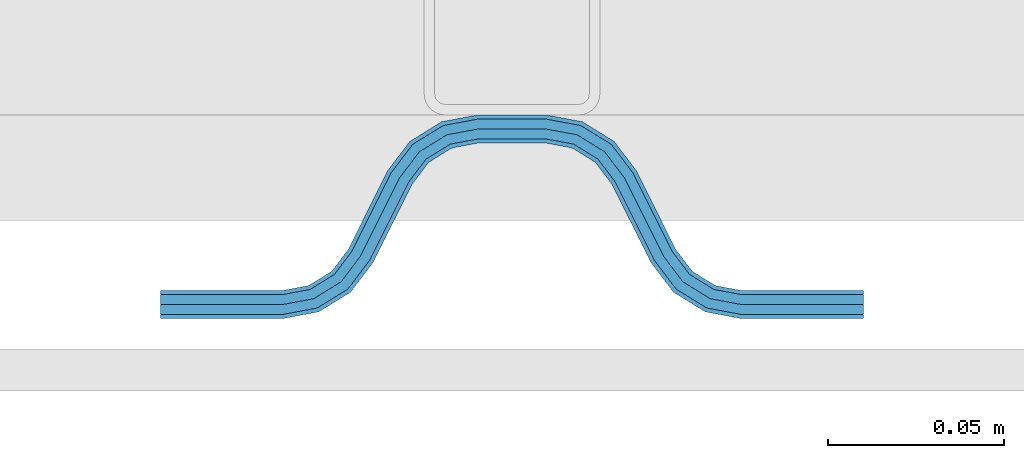
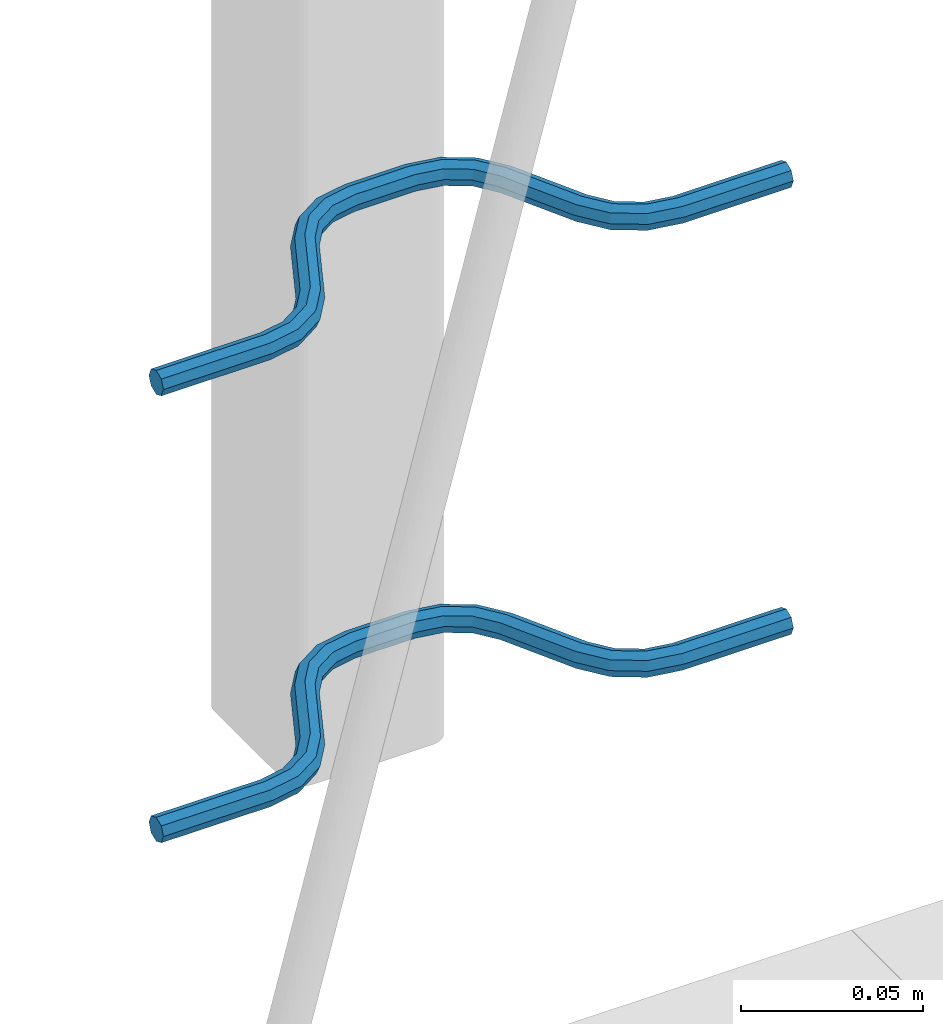
# One storey, part 5 of 5: 2 beams, 2 elements without a shape of their own.
"""IFC2X3 building model written with IfcOpenShell, lengths in millimetres."""

import ifcopenshell
import ifcopenshell.guid

model = None  # the IFC model being written
_history = None  # IfcOwnerHistory: only IFC2X3 demands one
_inside = {}  # id of a spatial element -> (the spatial element, [elements in it])
_under = {}  # id of a project, library or spatial element -> (it, [spatial elements below it])
_declared = {}  # id of a project -> (the project, [libraries it declares])
_typed = {}  # id of a type object -> (the type object, [elements of that type])
_made_of = {}  # id of a material, layer set ... -> (it, [elements and type objects made of it])


def new_model(schema):
    """Start an empty IFC model of exactly this schema.

    Asked for "IFC4X3", IfcOpenShell would pick the latest addendum, in which some entities
    have other attributes; the version numbers below select the first issue.
    IFC2X3 requires an IfcOwnerHistory on every rooted entity: one is made here for all.
    """
    global model, _history
    if schema == "IFC4X3":
        model = ifcopenshell.file(schema_version=(4, 3, 0, 0))
    else:
        model = ifcopenshell.file(schema=schema)
    _inside.clear()
    _under.clear()
    _declared.clear()
    _typed.clear()
    _made_of.clear()
    _history = None
    if model.schema == "IFC2X3":
        org = make("IfcOrganization", Name="unknown")
        user = make(
            "IfcPersonAndOrganization",
            ThePerson=make("IfcPerson", FamilyName="unknown"),
            TheOrganization=org,
        )
        app = make(
            "IfcApplication",
            ApplicationDeveloper=org,
            Version="unknown",
            ApplicationFullName="unknown",
            ApplicationIdentifier="unknown",
        )
        _history = make(
            "IfcOwnerHistory",
            OwningUser=user,
            OwningApplication=app,
            ChangeAction="ADDED",
            CreationDate=0,
        )
    return model


def make(cls, **values):
    """One entity of the class cls with the attributes given. An attribute that is None is left unset."""
    return model.create_entity(
        cls, **{name: value for name, value in values.items() if value is not None}
    )


def rooted(cls, **values):
    """An entity with a GlobalId (a new one), such as an element, a storey or a relation."""
    return make(cls, GlobalId=ifcopenshell.guid.new(), OwnerHistory=_history, **values)


def si_unit(unit_type, name, prefix=None):
    """IfcSIUnit, for example si_unit("LENGTHUNIT", "METRE", prefix="MILLI")."""
    return make("IfcSIUnit", UnitType=unit_type, Prefix=prefix, Name=name)


def assignment(units):
    """IfcUnitAssignment: the units of a project."""
    return None if units is None else make("IfcUnitAssignment", Units=units)


def point(xyz):
    """IfcCartesianPoint."""
    return None if xyz is None else make("IfcCartesianPoint", Coordinates=xyz)


def direction(xyz):
    """IfcDirection."""
    return None if xyz is None else make("IfcDirection", DirectionRatios=xyz)


def frame(location, z_axis=None, x_axis=None):
    """IfcAxis2Placement3D, a coordinate frame: its origin and axes. An axis left out is left unset."""
    return make(
        "IfcAxis2Placement3D",
        Location=point(location),
        Axis=direction(z_axis),
        RefDirection=direction(x_axis),
    )


def origin_with_axes():
    """The frame at (0, 0, 0) with the z axis (0, 0, 1) and the x axis (1, 0, 0) written out."""
    return frame((0.0, 0.0, 0.0), z_axis=(0.0, 0.0, 1.0), x_axis=(1.0, 0.0, 0.0))


def place(relative_to, where):
    """IfcLocalPlacement: puts the frame where relative to a parent placement (None: the world)."""
    return make(
        "IfcLocalPlacement", PlacementRelTo=relative_to, RelativePlacement=where
    )


def context(
    kind, dimensions, precision=None, world=None, true_north=None, identifier=None
):
    """IfcGeometricRepresentationContext, for example the 3D "Model" context."""
    return make(
        "IfcGeometricRepresentationContext",
        ContextIdentifier=identifier,
        ContextType=kind,
        CoordinateSpaceDimension=dimensions,
        Precision=precision,
        WorldCoordinateSystem=world,
        TrueNorth=true_north,
    )


def subcontext(parent, identifier, kind, view, scale=None):
    """IfcGeometricRepresentationSubContext, for example "Body" below "Model"."""
    return make(
        "IfcGeometricRepresentationSubContext",
        ContextIdentifier=identifier,
        ContextType=kind,
        ParentContext=parent,
        TargetScale=scale,
        TargetView=view,
    )


def project(units=None, contexts=None):
    """IfcProject with its units and contexts."""
    return rooted(
        "IfcProject",
        Name="project",
        RepresentationContexts=contexts,
        UnitsInContext=assignment(units),
    )


def spatial(cls, under=None, at=None, **own):
    """A site, building, storey or space (cls), placed at a placement, below another one or the project."""
    s = rooted(cls, ObjectPlacement=at, **own)
    if under is not None:
        _under.setdefault(under.id(), (under, []))[1].append(s)
    return s


def faces_of(points, faces, orient=None, outer=None):
    """IfcFace entities. A face is a list of loops; a loop is a list of indices into points, from 0.

    orient and outer hold one flag for each loop. By default every Orientation is true, the
    first loop of a face is its IfcFaceOuterBound and the others are IfcFaceBound.
    """
    made = []
    for i, loops in enumerate(faces):
        bounds = []
        for j, loop in enumerate(loops):
            is_outer = j == 0 if outer is None else outer[i][j]
            bounds.append(
                make(
                    "IfcFaceOuterBound" if is_outer else "IfcFaceBound",
                    Bound=make("IfcPolyLoop", Polygon=[points[k] for k in loop]),
                    Orientation=True if orient is None else orient[i][j],
                )
            )
        made.append(make("IfcFace", Bounds=bounds))
    return made


def faceted_brep(points, faces, orient=None, outer=None, voids=None):
    """IfcFacetedBrep: a solid bounded by flat faces; with voids (closed shells), ...WithVoids."""
    shared = [point(p) for p in points]
    hull = make("IfcClosedShell", CfsFaces=faces_of(shared, faces, orient, outer))
    if voids is None:
        return make("IfcFacetedBrep", Outer=hull)
    return make(
        "IfcFacetedBrepWithVoids",
        Outer=hull,
        Voids=[
            make(cls, CfsFaces=faces_of(shared, fs, o, b)) for cls, fs, o, b in voids
        ],
    )


def shape(context_of_items, identifier, shape_type, items):
    """IfcShapeRepresentation: the items that make up one representation, for example the "Body"."""
    return make(
        "IfcShapeRepresentation",
        ContextOfItems=context_of_items,
        RepresentationIdentifier=identifier,
        RepresentationType=shape_type,
        Items=items,
    )


def material(Name=None, Category=None):
    """IfcMaterial."""
    return make("IfcMaterial", Name=Name, Category=Category)


def made_of(thing, what):
    """Note that an element or type object is made of a material, layer set ...; save() writes the relation."""
    if what is not None:
        _made_of.setdefault(what.id(), (what, []))[1].append(thing)
    return thing


def type_object(cls, material=None, **own):
    """A type object (cls), such as IfcWallType, which elements share."""
    return made_of(rooted(cls, **own), material)


def element(
    cls,
    number,
    at=None,
    inside=None,
    cuts=None,
    type_object=None,
    material=None,
    context=None,
    identifier="Body",
    shape_type=None,
    held_by="IfcProductDefinitionShape",
    body=None,
    shapes=None,
    **own,
):
    """One element of the class cls, such as IfcWall. Its Tag is "e" and its number.

    at: its placement. inside: the storey or other place that contains it. cuts: it is an
    opening in that element (IfcRelVoidsElement). A single representation is given by context,
    identifier, shape_type and body (its items); several are given by shapes. held_by: the class
    of the entity that holds the representations. save() writes the other relations.
    """
    e = rooted(cls, Tag="e%d" % number, ObjectPlacement=at, **own)
    if body is not None:
        shapes = [shape(context, identifier, shape_type, body)]
    if shapes is not None:
        e.Representation = make(held_by, Representations=shapes)
    if inside is not None:
        _inside.setdefault(inside.id(), (inside, []))[1].append(e)
    if cuts is not None:
        rooted(
            "IfcRelVoidsElement", RelatingBuildingElement=cuts, RelatedOpeningElement=e
        )
    if type_object is not None:
        _typed.setdefault(type_object.id(), (type_object, []))[1].append(e)
    return made_of(e, material)


def aggregate(whole, parts):
    """IfcRelAggregates: a whole, such as a stair, and the parts it consists of."""
    return rooted("IfcRelAggregates", RelatingObject=whole, RelatedObjects=parts)


def save(model, path):
    """Write the relations noted so far, then the file.

    IfcRelAggregates (storeys below a building ...), IfcRelContainedInSpatialStructure (elements
    in a storey), IfcRelDefinesByType, IfcRelAssociatesMaterial and IfcRelDeclares: one each for
    every whole, place, type object, material and project.
    """
    for whole, parts in _under.values():
        aggregate(whole, parts)
    for where, things in _inside.values():
        rooted(
            "IfcRelContainedInSpatialStructure",
            RelatedElements=things,
            RelatingStructure=where,
        )
    for kind, things in _typed.values():
        rooted("IfcRelDefinesByType", RelatedObjects=things, RelatingType=kind)
    for what, things in _made_of.values():
        rooted("IfcRelAssociatesMaterial", RelatedObjects=things, RelatingMaterial=what)
    for by, libraries in _declared.values():
        rooted("IfcRelDeclares", RelatingContext=by, RelatedDefinitions=libraries)
    model.write(path)


model = new_model("IFC2X3")

# Units and contexts
model_context = context("Model", 3, precision=1e-05, world=origin_with_axes())
body_context = subcontext(model_context, "Body", "Model", "MODEL_VIEW")
ifc_project = project(units=[si_unit("LENGTHUNIT", "METRE", prefix="MILLI"), si_unit("AREAUNIT", "SQUARE_METRE"), si_unit("VOLUMEUNIT", "CUBIC_METRE"), si_unit("MASSUNIT", "GRAM", prefix="KILO"), si_unit("TIMEUNIT", "SECOND"), si_unit("PLANEANGLEUNIT", "RADIAN"), si_unit("SOLIDANGLEUNIT", "STERADIAN"), si_unit("THERMODYNAMICTEMPERATUREUNIT", "DEGREE_CELSIUS"), si_unit("LUMINOUSINTENSITYUNIT", "LUMEN")], contexts=[model_context])

# Site, building, storey
site_placement = place(None, origin_with_axes())
site = spatial("IfcSite", under=ifc_project, at=site_placement, CompositionType="ELEMENT")
building_placement = place(site_placement, origin_with_axes())
building = spatial("IfcBuilding", under=site, at=building_placement, Name="Undefined", CompositionType="ELEMENT")
storey_placement = place(building_placement, origin_with_axes())
storey = spatial("IfcBuildingStorey", under=building, at=storey_placement, Name="Undefined", CompositionType="ELEMENT", Elevation=0.0)

# Assembly, beam
assembly_1_placement = place(storey_placement, origin_with_axes())
assembly_1 = element("IfcElementAssembly", 1, at=assembly_1_placement, inside=storey, Name="Steel Assembly", AssemblyPlace="NOTDEFINED", PredefinedType="NOTDEFINED")
ifc_material = material(Name="REBAR/A500HW")
beam_type = type_object("IfcBeamType", Name="D8", PredefinedType="NOTDEFINED")
beam_1_placement = place(assembly_1_placement, frame((38820.0028937636, 6595.91435022471, 2430.99992151562), z_axis=(0.0, 0.0, 1.0), x_axis=(-0.999999999544916, 3.01689999841786e-05, 0.0)))
beam_1 = element("IfcBeam", 2, at=beam_1_placement, type_object=beam_type, material=ifc_material, Name="AnchorRebar", ObjectType="D8", context=body_context, shape_type="Brep", body=[
    faceted_brep([(2.18278728425503e-11, -4.0, 0.0), (1.45519152283669e-11, -2.82842712474576, -2.82842712474621), (34.5491497807598, -2.82842712464117, -2.82842712474621), (34.5491497803741, -3.99999999989996, 0.0), (7.27595761418343e-12, 9.09494701772928e-13, -4.0), (34.5491497807452, 1.04591890703887e-10, -4.0), (-7.27595761418343e-12, 2.82842712474667, -2.82842712474621), (34.5491497807379, 2.82842712485035, -2.82842712474621), (-1.45519152283669e-11, 4.00000000000091, 0.0), (34.5491497807307, 4.00000000010459, 0.0), (-7.27595761418343e-12, 2.82842712474667, 2.82842712474621), (34.5491497807379, 2.82842712485035, 2.82842712474621), (7.27595761418343e-12, 9.09494701772928e-13, 4.0), (34.5491497807452, 1.04591890703887e-10, 4.0), (1.45519152283669e-11, -2.82842712474576, 2.82842712474621), (34.5491497807598, -2.82842712464117, 2.82842712474621), (45.0102956729461, 2.04744769146328, 0.0), (44.5876751635806, 0.954756103187719, -2.82842712474621), (43.5673789981374, -1.68323474873705, -4.0), (42.5470828327016, -4.32122560064909, -2.82842712474621), (42.1244623233288, -5.41391718892919, 0.0), (42.5470828327016, -4.32122560064909, 2.82842712474621), (43.5673789981374, -1.68323474873705, 4.0), (44.5876751635806, 0.954756103187719, 2.82842712474621), (53.2744249666721, -4.41395070840099, 2.82842712474621), (54.0627564232709, -3.54728092319965, 0.0), (51.3712244725102, -6.5062766579249, 4.0), (49.4680239783702, -8.5986026074479, 2.82842712474621), (48.6796925217786, -9.46527239263742, 0.0), (49.4680239783702, -8.5986026074479, -2.82842712474621), (51.3712244725102, -6.5062766579249, -4.0), (53.2744249666721, -4.41395070840099, -2.82842712474621), (59.4396520595255, -12.5547498008955, 2.82842712474621), (60.4875387112043, -12.0308065146473, 0.0), (56.9098298931422, -13.8196607884638, 4.0), (54.3800077267733, -15.0845717760394, 2.82842712474621), (53.3321210758877, -15.6085150625322, 0.0), (54.3800077267733, -15.0845717760394, -2.82842712474621), (56.9098298931422, -13.8196607884638, -4.0), (59.4396520595255, -12.5547498008955, -2.82842712474621), (65.5603461600695, -37.4452503321118, -2.82842712474621), (64.5124595074303, -37.9691936178024, 0.0), (68.0901683264674, -36.1803393445653, -4.0), (70.6199904928581, -34.9154283570169, -2.82842712474621), (71.6678771445659, -34.3914850707815, 0.0), (70.6199904928581, -34.9154283570169, 2.82842712474621), (68.0901683264674, -36.1803393445653, 4.0), (65.5603461600695, -37.4452503321118, 2.82842712474621), (76.3203054721744, -40.5347275358363, 0.0), (75.53197400301, -41.4013973095998, -2.82842712474621), (73.6287734785365, -43.4937232315178, -4.0), (71.7255729540339, -45.5860491534368, -2.82842712474621), (70.9372414848622, -46.4527189272021, 0.0), (71.7255729540339, -45.5860491534368, 2.82842712474621), (73.6287734785365, -43.4937232315178, 4.0), (75.53197400301, -41.4013973095998, 2.82842712474621), (82.4529147876528, -45.6787743011646, 2.82842712474621), (82.8755353286688, -44.5860827251363, 0.0), (81.4326185457539, -48.3167651235117, 4.0), (80.4123223038914, -50.9547559458606, 2.82842712474621), (79.9897017628609, -52.0474475218944, 0.0), (80.4123223038914, -50.9547559458606, -2.82842712474621), (81.4326185457539, -48.3167651235117, -4.0), (82.4529147876528, -45.6787743011646, -2.82842712474621), (90.4508474762042, -47.1715730090009, 2.82842712474621), (90.450847527085, -46.0000001337467, 0.0), (90.4508473533715, -50.0000001337448, 4.0), (90.4508472305388, -52.8284272584888, 2.82842712474621), (90.4508471810695, -54.0000001334174, 0.0), (90.4508472305388, -52.8284272584888, -2.82842712474621), (90.4508473533715, -50.0000001337448, -4.0), (90.4508474762042, -47.1715730090009, -2.82842712474621), (109.549147671336, -52.8284280870112, -2.82842712474621), (109.549147618905, -54.0000009615069, 0.0), (109.549147794081, -50.0000009622636, -4.0), (109.549147916834, -47.1715738375178, -2.82842712474621), (109.549147967678, -46.0000009622645, 0.0), (109.549147916834, -47.1715738375178, 2.82842712474621), (109.549147794081, -50.0000009622636, 4.0), (109.549147671336, -52.8284280870112, 2.82842712474621), (120.010293517997, -52.0474491371906, 0.0), (119.587673059228, -50.9547575293454, 2.82842712474621), (118.567377015977, -48.3167666302043, 4.0), (117.547080972698, -45.6787757310603, 2.82842712474621), (117.124460513915, -44.5860841232243, 0.0), (117.547080972698, -45.6787757310603, -2.82842712474621), (118.567377015977, -48.3167666302043, -4.0), (119.587673059228, -50.9547575293454, -2.82842712474621), (128.274423051233, -45.586051174274, -2.82842712474621), (129.062754465187, -46.4527209982516, 0.0), (126.371222660055, -43.4937251311139, -4.0), (124.468022268862, -41.4013990879685, -2.82842712474621), (123.679690854915, -40.5347292639935, 0.0), (124.468022268862, -41.4013990879685, 2.82842712474621), (126.371222660055, -43.4937251311139, 4.0), (128.274423051233, -45.586051174274, 2.82842712474621), (134.439650508568, -37.4452524573453, -2.82842712474621), (135.48753713489, -37.9691957980858, 0.0), (131.909828408126, -36.1803413379666, -4.0), (129.380006307663, -34.9154302185971, -2.82842712474621), (128.332119683255, -34.3914868777574, 0.0), (129.380006307663, -34.9154302185971, 2.82842712474621), (131.909828408126, -36.1803413379666, 4.0), (134.439650508568, -37.4452524573453, 2.82842712474621), (145.619991978041, -15.0845707426524, -2.82842712474621), (146.66787860055, -15.6085140834621, 0.0), (143.09016987752, -13.8196596233502, -4.0), (140.560347777006, -12.5547485040488, -2.82842712474621), (139.512461152583, -12.0308051632373, 0.0), (140.560347777006, -12.5547485040488, 2.82842712474621), (143.09016987752, -13.8196596233502, 4.0), (145.619991978041, -15.0845707426524, 2.82842712474621), (151.32030720418, -9.46527190098914, 0.0), (150.531975777645, -8.59860208845657, 2.82842712474621), (148.628775356075, -6.50627607293518, 4.0), (146.725574934491, -4.41395005741106, 2.82842712474621), (145.937243507949, -3.5472802448794, 0.0), (146.725574934491, -4.41395005741106, -2.82842712474621), (148.628775356075, -6.50627607293518, -4.0), (150.531975777645, -8.59860208845657, -2.82842712474621), (157.452916713031, -4.32122546032224, -2.82842712474621), (157.875537203472, -5.41391705590922, 0.0), (156.432620593252, -1.68323459075145, -4.0), (155.412324473487, 0.954756278815694, -2.82842712474621), (154.989703983039, 2.04744787441086, 0.0), (155.412324473487, 0.954756278815694, 2.82842712474621), (156.432620593252, -1.68323459075145, 4.0), (157.452916713031, -4.32122546032224, 2.82842712474621), (165.450849406719, -2.82842712265665, -2.82842712474621), (165.4508494084, -3.99999999905958, 0.0), (165.450849406632, 2.07910488825291e-09, -4.0), (165.45084940653, 2.82842712682032, -2.82842712474621), (165.450849406501, 4.00000000206637, 0.0), (165.45084940653, 2.82842712682032, 2.82842712474621), (165.450849406632, 2.07910488825291e-09, 4.0), (165.450849406719, -2.82842712265665, 2.82842712474621), (200.00000008905, -2.8284271237826, -2.82842712474621), (200.00000008905, -3.99999999903685, 0.0), (200.00000008905, 9.64064383879304e-10, -4.0), (200.00000008905, 2.82842712570982, -2.82842712474621), (200.00000008905, 4.00000000096315, 0.0), (200.00000008905, 2.82842712570982, 2.82842712474621), (200.00000008905, 9.64064383879304e-10, 4.0), (200.00000008905, -2.8284271237826, 2.82842712474621)], [[[0, 1, 2, 3]], [[1, 4, 5, 2]], [[4, 6, 7, 5]], [[6, 8, 9, 7]], [[8, 10, 11, 9]], [[10, 12, 13, 11]], [[12, 14, 15, 13]], [[14, 0, 3, 15]], [[14, 12, 10, 8, 6, 4, 1, 0]], [[7, 9, 16, 17]], [[5, 7, 17, 18]], [[2, 5, 18, 19]], [[3, 2, 19, 20]], [[15, 3, 20, 21]], [[13, 15, 21, 22]], [[11, 13, 22, 23]], [[9, 11, 23, 16]], [[23, 24, 25, 16]], [[22, 26, 24, 23]], [[21, 27, 26, 22]], [[20, 28, 27, 21]], [[19, 29, 28, 20]], [[18, 30, 29, 19]], [[17, 31, 30, 18]], [[16, 25, 31, 17]], [[24, 32, 33, 25]], [[26, 34, 32, 24]], [[27, 35, 34, 26]], [[28, 36, 35, 27]], [[29, 37, 36, 28]], [[30, 38, 37, 29]], [[31, 39, 38, 30]], [[25, 33, 39, 31]], [[36, 37, 40, 41]], [[37, 38, 42, 40]], [[38, 39, 43, 42]], [[39, 33, 44, 43]], [[33, 32, 45, 44]], [[32, 34, 46, 45]], [[34, 35, 47, 46]], [[35, 36, 41, 47]], [[43, 44, 48, 49]], [[42, 43, 49, 50]], [[40, 42, 50, 51]], [[41, 40, 51, 52]], [[47, 41, 52, 53]], [[46, 47, 53, 54]], [[45, 46, 54, 55]], [[44, 45, 55, 48]], [[55, 56, 57, 48]], [[54, 58, 56, 55]], [[53, 59, 58, 54]], [[52, 60, 59, 53]], [[51, 61, 60, 52]], [[50, 62, 61, 51]], [[49, 63, 62, 50]], [[48, 57, 63, 49]], [[56, 64, 65, 57]], [[58, 66, 64, 56]], [[59, 67, 66, 58]], [[60, 68, 67, 59]], [[61, 69, 68, 60]], [[62, 70, 69, 61]], [[63, 71, 70, 62]], [[57, 65, 71, 63]], [[68, 69, 72, 73]], [[69, 70, 74, 72]], [[70, 71, 75, 74]], [[71, 65, 76, 75]], [[65, 64, 77, 76]], [[64, 66, 78, 77]], [[66, 67, 79, 78]], [[67, 68, 73, 79]], [[79, 73, 80, 81]], [[78, 79, 81, 82]], [[77, 78, 82, 83]], [[76, 77, 83, 84]], [[75, 76, 84, 85]], [[74, 75, 85, 86]], [[72, 74, 86, 87]], [[73, 72, 87, 80]], [[87, 88, 89, 80]], [[86, 90, 88, 87]], [[85, 91, 90, 86]], [[84, 92, 91, 85]], [[83, 93, 92, 84]], [[82, 94, 93, 83]], [[81, 95, 94, 82]], [[80, 89, 95, 81]], [[88, 96, 97, 89]], [[90, 98, 96, 88]], [[91, 99, 98, 90]], [[92, 100, 99, 91]], [[93, 101, 100, 92]], [[94, 102, 101, 93]], [[95, 103, 102, 94]], [[89, 97, 103, 95]], [[97, 96, 104, 105]], [[96, 98, 106, 104]], [[98, 99, 107, 106]], [[99, 100, 108, 107]], [[100, 101, 109, 108]], [[101, 102, 110, 109]], [[102, 103, 111, 110]], [[103, 97, 105, 111]], [[111, 105, 112, 113]], [[110, 111, 113, 114]], [[109, 110, 114, 115]], [[108, 109, 115, 116]], [[107, 108, 116, 117]], [[106, 107, 117, 118]], [[104, 106, 118, 119]], [[105, 104, 119, 112]], [[119, 120, 121, 112]], [[118, 122, 120, 119]], [[117, 123, 122, 118]], [[116, 124, 123, 117]], [[115, 125, 124, 116]], [[114, 126, 125, 115]], [[113, 127, 126, 114]], [[112, 121, 127, 113]], [[120, 128, 129, 121]], [[122, 130, 128, 120]], [[123, 131, 130, 122]], [[124, 132, 131, 123]], [[125, 133, 132, 124]], [[126, 134, 133, 125]], [[127, 135, 134, 126]], [[121, 129, 135, 127]], [[129, 128, 136, 137]], [[128, 130, 138, 136]], [[130, 131, 139, 138]], [[131, 132, 140, 139]], [[132, 133, 141, 140]], [[133, 134, 142, 141]], [[134, 135, 143, 142]], [[135, 129, 137, 143]], [[138, 139, 140, 141, 142, 143, 137, 136]]]),
])
aggregate(assembly_1, [beam_1])

assembly_2_placement = place(storey_placement, origin_with_axes())
assembly_2 = element("IfcElementAssembly", 3, at=assembly_2_placement, inside=storey, Name="Steel Assembly", AssemblyPlace="NOTDEFINED", PredefinedType="NOTDEFINED")
beam_2_placement = place(assembly_2_placement, frame((38820.0028937636, 6595.91435022471, 2580.99992151562), z_axis=(0.0, 0.0, 1.0), x_axis=(-0.999999999544916, 3.01689999841786e-05, 0.0)))
beam_2 = element("IfcBeam", 4, at=beam_2_placement, type_object=beam_type, material=ifc_material, Name="AnchorRebar", ObjectType="D8", context=body_context, shape_type="Brep", body=[
    faceted_brep([(2.18278728425503e-11, -4.0, 0.0), (1.45519152283669e-11, -2.82842712474576, -2.82842712474621), (34.5491497807598, -2.82842712464117, -2.82842712474621), (34.5491497803741, -3.99999999989996, 0.0), (7.27595761418343e-12, 9.09494701772928e-13, -4.0), (34.5491497807452, 1.04591890703887e-10, -4.0), (-7.27595761418343e-12, 2.82842712474667, -2.82842712474621), (34.5491497807379, 2.82842712485035, -2.82842712474621), (-1.45519152283669e-11, 4.00000000000091, 0.0), (34.5491497807307, 4.00000000010459, 0.0), (-7.27595761418343e-12, 2.82842712474667, 2.82842712474621), (34.5491497807379, 2.82842712485035, 2.82842712474621), (7.27595761418343e-12, 9.09494701772928e-13, 4.0), (34.5491497807452, 1.04591890703887e-10, 4.0), (1.45519152283669e-11, -2.82842712474576, 2.82842712474621), (34.5491497807598, -2.82842712464117, 2.82842712474621), (45.0102956729461, 2.04744769146328, 0.0), (44.5876751635806, 0.954756103187719, -2.82842712474621), (43.5673789981374, -1.68323474873705, -4.0), (42.5470828327016, -4.32122560064909, -2.82842712474621), (42.1244623233288, -5.41391718892919, 0.0), (42.5470828327016, -4.32122560064909, 2.82842712474621), (43.5673789981374, -1.68323474873705, 4.0), (44.5876751635806, 0.954756103187719, 2.82842712474621), (53.2744249666721, -4.41395070840099, 2.82842712474621), (54.0627564232709, -3.54728092319965, 0.0), (51.3712244725102, -6.5062766579249, 4.0), (49.4680239783702, -8.5986026074479, 2.82842712474621), (48.6796925217786, -9.46527239263742, 0.0), (49.4680239783702, -8.5986026074479, -2.82842712474621), (51.3712244725102, -6.5062766579249, -4.0), (53.2744249666721, -4.41395070840099, -2.82842712474621), (59.4396520595255, -12.5547498008955, 2.82842712474621), (60.4875387112043, -12.0308065146473, 0.0), (56.9098298931422, -13.8196607884638, 4.0), (54.3800077267733, -15.0845717760394, 2.82842712474621), (53.3321210758877, -15.6085150625322, 0.0), (54.3800077267733, -15.0845717760394, -2.82842712474621), (56.9098298931422, -13.8196607884638, -4.0), (59.4396520595255, -12.5547498008955, -2.82842712474621), (65.5603461600695, -37.4452503321118, -2.82842712474621), (64.5124595074303, -37.9691936178024, 0.0), (68.0901683264674, -36.1803393445653, -4.0), (70.6199904928581, -34.9154283570169, -2.82842712474621), (71.6678771445659, -34.3914850707815, 0.0), (70.6199904928581, -34.9154283570169, 2.82842712474621), (68.0901683264674, -36.1803393445653, 4.0), (65.5603461600695, -37.4452503321118, 2.82842712474621), (76.3203054721744, -40.5347275358363, 0.0), (75.53197400301, -41.4013973095998, -2.82842712474621), (73.6287734785365, -43.4937232315178, -4.0), (71.7255729540339, -45.5860491534368, -2.82842712474621), (70.9372414848622, -46.4527189272021, 0.0), (71.7255729540339, -45.5860491534368, 2.82842712474621), (73.6287734785365, -43.4937232315178, 4.0), (75.53197400301, -41.4013973095998, 2.82842712474621), (82.4529147876528, -45.6787743011646, 2.82842712474621), (82.8755353286688, -44.5860827251363, 0.0), (81.4326185457539, -48.3167651235117, 4.0), (80.4123223038914, -50.9547559458606, 2.82842712474621), (79.9897017628609, -52.0474475218944, 0.0), (80.4123223038914, -50.9547559458606, -2.82842712474621), (81.4326185457539, -48.3167651235117, -4.0), (82.4529147876528, -45.6787743011646, -2.82842712474621), (90.4508474762042, -47.1715730090009, 2.82842712474621), (90.450847527085, -46.0000001337467, 0.0), (90.4508473533715, -50.0000001337448, 4.0), (90.4508472305388, -52.8284272584888, 2.82842712474621), (90.4508471810695, -54.0000001334174, 0.0), (90.4508472305388, -52.8284272584888, -2.82842712474621), (90.4508473533715, -50.0000001337448, -4.0), (90.4508474762042, -47.1715730090009, -2.82842712474621), (109.549147671336, -52.8284280870112, -2.82842712474621), (109.549147618905, -54.0000009615069, 0.0), (109.549147794081, -50.0000009622636, -4.0), (109.549147916834, -47.1715738375178, -2.82842712474621), (109.549147967678, -46.0000009622645, 0.0), (109.549147916834, -47.1715738375178, 2.82842712474621), (109.549147794081, -50.0000009622636, 4.0), (109.549147671336, -52.8284280870112, 2.82842712474621), (120.010293517997, -52.0474491371906, 0.0), (119.587673059228, -50.9547575293454, 2.82842712474621), (118.567377015977, -48.3167666302043, 4.0), (117.547080972698, -45.6787757310603, 2.82842712474621), (117.124460513915, -44.5860841232243, 0.0), (117.547080972698, -45.6787757310603, -2.82842712474621), (118.567377015977, -48.3167666302043, -4.0), (119.587673059228, -50.9547575293454, -2.82842712474621), (128.274423051233, -45.586051174274, -2.82842712474621), (129.062754465187, -46.4527209982516, 0.0), (126.371222660055, -43.4937251311139, -4.0), (124.468022268862, -41.4013990879685, -2.82842712474621), (123.679690854915, -40.5347292639935, 0.0), (124.468022268862, -41.4013990879685, 2.82842712474621), (126.371222660055, -43.4937251311139, 4.0), (128.274423051233, -45.586051174274, 2.82842712474621), (134.439650508568, -37.4452524573453, -2.82842712474621), (135.48753713489, -37.9691957980858, 0.0), (131.909828408126, -36.1803413379666, -4.0), (129.380006307663, -34.9154302185971, -2.82842712474621), (128.332119683255, -34.3914868777574, 0.0), (129.380006307663, -34.9154302185971, 2.82842712474621), (131.909828408126, -36.1803413379666, 4.0), (134.439650508568, -37.4452524573453, 2.82842712474621), (145.619991978041, -15.0845707426524, -2.82842712474621), (146.66787860055, -15.6085140834621, 0.0), (143.09016987752, -13.8196596233502, -4.0), (140.560347777006, -12.5547485040488, -2.82842712474621), (139.512461152583, -12.0308051632373, 0.0), (140.560347777006, -12.5547485040488, 2.82842712474621), (143.09016987752, -13.8196596233502, 4.0), (145.619991978041, -15.0845707426524, 2.82842712474621), (151.32030720418, -9.46527190098914, 0.0), (150.531975777645, -8.59860208845657, 2.82842712474621), (148.628775356075, -6.50627607293518, 4.0), (146.725574934491, -4.41395005741106, 2.82842712474621), (145.937243507949, -3.5472802448794, 0.0), (146.725574934491, -4.41395005741106, -2.82842712474621), (148.628775356075, -6.50627607293518, -4.0), (150.531975777645, -8.59860208845657, -2.82842712474621), (157.452916713031, -4.32122546032224, -2.82842712474621), (157.875537203472, -5.41391705590922, 0.0), (156.432620593252, -1.68323459075145, -4.0), (155.412324473487, 0.954756278815694, -2.82842712474621), (154.989703983039, 2.04744787441086, 0.0), (155.412324473487, 0.954756278815694, 2.82842712474621), (156.432620593252, -1.68323459075145, 4.0), (157.452916713031, -4.32122546032224, 2.82842712474621), (165.450849406719, -2.82842712265665, -2.82842712474621), (165.4508494084, -3.99999999905958, 0.0), (165.450849406632, 2.07910488825291e-09, -4.0), (165.45084940653, 2.82842712682032, -2.82842712474621), (165.450849406501, 4.00000000206637, 0.0), (165.45084940653, 2.82842712682032, 2.82842712474621), (165.450849406632, 2.07910488825291e-09, 4.0), (165.450849406719, -2.82842712265665, 2.82842712474621), (200.00000008905, -2.8284271237826, -2.82842712474621), (200.00000008905, -3.99999999903685, 0.0), (200.00000008905, 9.64064383879304e-10, -4.0), (200.00000008905, 2.82842712570982, -2.82842712474621), (200.00000008905, 4.00000000096315, 0.0), (200.00000008905, 2.82842712570982, 2.82842712474621), (200.00000008905, 9.64064383879304e-10, 4.0), (200.00000008905, -2.8284271237826, 2.82842712474621)], [[[0, 1, 2, 3]], [[1, 4, 5, 2]], [[4, 6, 7, 5]], [[6, 8, 9, 7]], [[8, 10, 11, 9]], [[10, 12, 13, 11]], [[12, 14, 15, 13]], [[14, 0, 3, 15]], [[14, 12, 10, 8, 6, 4, 1, 0]], [[7, 9, 16, 17]], [[5, 7, 17, 18]], [[2, 5, 18, 19]], [[3, 2, 19, 20]], [[15, 3, 20, 21]], [[13, 15, 21, 22]], [[11, 13, 22, 23]], [[9, 11, 23, 16]], [[23, 24, 25, 16]], [[22, 26, 24, 23]], [[21, 27, 26, 22]], [[20, 28, 27, 21]], [[19, 29, 28, 20]], [[18, 30, 29, 19]], [[17, 31, 30, 18]], [[16, 25, 31, 17]], [[24, 32, 33, 25]], [[26, 34, 32, 24]], [[27, 35, 34, 26]], [[28, 36, 35, 27]], [[29, 37, 36, 28]], [[30, 38, 37, 29]], [[31, 39, 38, 30]], [[25, 33, 39, 31]], [[36, 37, 40, 41]], [[37, 38, 42, 40]], [[38, 39, 43, 42]], [[39, 33, 44, 43]], [[33, 32, 45, 44]], [[32, 34, 46, 45]], [[34, 35, 47, 46]], [[35, 36, 41, 47]], [[43, 44, 48, 49]], [[42, 43, 49, 50]], [[40, 42, 50, 51]], [[41, 40, 51, 52]], [[47, 41, 52, 53]], [[46, 47, 53, 54]], [[45, 46, 54, 55]], [[44, 45, 55, 48]], [[55, 56, 57, 48]], [[54, 58, 56, 55]], [[53, 59, 58, 54]], [[52, 60, 59, 53]], [[51, 61, 60, 52]], [[50, 62, 61, 51]], [[49, 63, 62, 50]], [[48, 57, 63, 49]], [[56, 64, 65, 57]], [[58, 66, 64, 56]], [[59, 67, 66, 58]], [[60, 68, 67, 59]], [[61, 69, 68, 60]], [[62, 70, 69, 61]], [[63, 71, 70, 62]], [[57, 65, 71, 63]], [[68, 69, 72, 73]], [[69, 70, 74, 72]], [[70, 71, 75, 74]], [[71, 65, 76, 75]], [[65, 64, 77, 76]], [[64, 66, 78, 77]], [[66, 67, 79, 78]], [[67, 68, 73, 79]], [[79, 73, 80, 81]], [[78, 79, 81, 82]], [[77, 78, 82, 83]], [[76, 77, 83, 84]], [[75, 76, 84, 85]], [[74, 75, 85, 86]], [[72, 74, 86, 87]], [[73, 72, 87, 80]], [[87, 88, 89, 80]], [[86, 90, 88, 87]], [[85, 91, 90, 86]], [[84, 92, 91, 85]], [[83, 93, 92, 84]], [[82, 94, 93, 83]], [[81, 95, 94, 82]], [[80, 89, 95, 81]], [[88, 96, 97, 89]], [[90, 98, 96, 88]], [[91, 99, 98, 90]], [[92, 100, 99, 91]], [[93, 101, 100, 92]], [[94, 102, 101, 93]], [[95, 103, 102, 94]], [[89, 97, 103, 95]], [[97, 96, 104, 105]], [[96, 98, 106, 104]], [[98, 99, 107, 106]], [[99, 100, 108, 107]], [[100, 101, 109, 108]], [[101, 102, 110, 109]], [[102, 103, 111, 110]], [[103, 97, 105, 111]], [[111, 105, 112, 113]], [[110, 111, 113, 114]], [[109, 110, 114, 115]], [[108, 109, 115, 116]], [[107, 108, 116, 117]], [[106, 107, 117, 118]], [[104, 106, 118, 119]], [[105, 104, 119, 112]], [[119, 120, 121, 112]], [[118, 122, 120, 119]], [[117, 123, 122, 118]], [[116, 124, 123, 117]], [[115, 125, 124, 116]], [[114, 126, 125, 115]], [[113, 127, 126, 114]], [[112, 121, 127, 113]], [[120, 128, 129, 121]], [[122, 130, 128, 120]], [[123, 131, 130, 122]], [[124, 132, 131, 123]], [[125, 133, 132, 124]], [[126, 134, 133, 125]], [[127, 135, 134, 126]], [[121, 129, 135, 127]], [[129, 128, 136, 137]], [[128, 130, 138, 136]], [[130, 131, 139, 138]], [[131, 132, 140, 139]], [[132, 133, 141, 140]], [[133, 134, 142, 141]], [[134, 135, 143, 142]], [[135, 129, 137, 143]], [[138, 139, 140, 141, 142, 143, 137, 136]]]),
])
aggregate(assembly_2, [beam_2])

save(model, "model.ifc")
